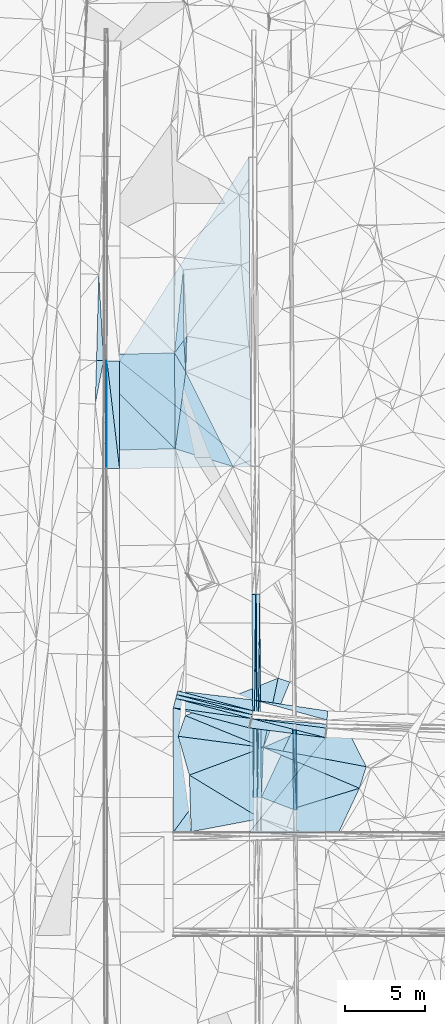
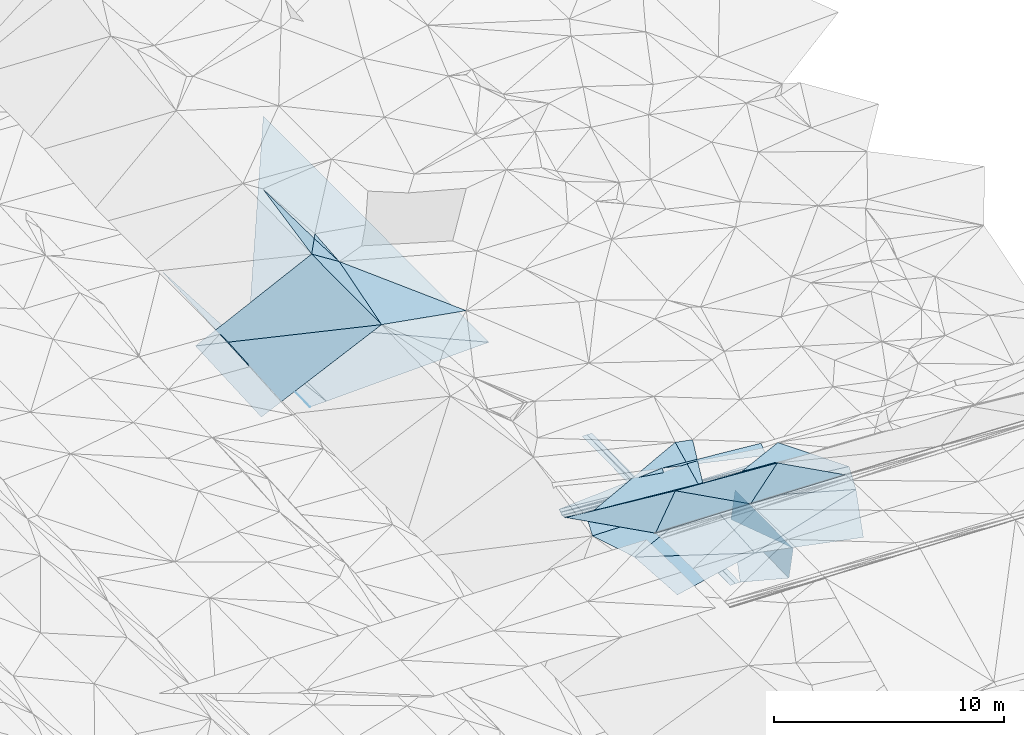
# One storey, part 114 of 275: 46 plates.
"""IFC2X3 building model written with IfcOpenShell, lengths in millimetres."""

from ifc_helpers import new_model, si_unit, frame, origin_with_axes, place, context, subcontext, project, spatial, polyline, outline, extrude, material, type_object, element, save


model = new_model("IFC2X3")

# Units and contexts
model_context = context("Model", 3, precision=1e-05, world=origin_with_axes())
body_context = subcontext(model_context, "Body", "Model", "MODEL_VIEW")
ifc_project = project(units=[si_unit("LENGTHUNIT", "METRE", prefix="MILLI"), si_unit("AREAUNIT", "SQUARE_METRE"), si_unit("VOLUMEUNIT", "CUBIC_METRE"), si_unit("MASSUNIT", "GRAM", prefix="KILO"), si_unit("TIMEUNIT", "SECOND"), si_unit("PLANEANGLEUNIT", "RADIAN"), si_unit("SOLIDANGLEUNIT", "STERADIAN"), si_unit("THERMODYNAMICTEMPERATUREUNIT", "DEGREE_CELSIUS"), si_unit("LUMINOUSINTENSITYUNIT", "LUMEN")], contexts=[model_context])

# Site, building, storey
site_placement = place(None, origin_with_axes())
site = spatial("IfcSite", under=ifc_project, at=site_placement, CompositionType="ELEMENT")
building_placement = place(site_placement, origin_with_axes())
building = spatial("IfcBuilding", under=site, at=building_placement, Name="Undefined", CompositionType="ELEMENT")
storey_placement = place(building_placement, origin_with_axes())
storey = spatial("IfcBuildingStorey", under=building, at=storey_placement, Name="Undefined", CompositionType="ELEMENT", Elevation=0.0)

# Plates
ifc_material = material()
plate_type_1 = type_object("IfcPlateType", PredefinedType="NOTDEFINED")
plate_1_placement = place(storey_placement, frame((-45539.6443262648, 72967.2701989383, 44320.8392892006), z_axis=(0.989902546953071, 0.00964893365161837, -0.141420810403599), x_axis=(0.00717849200956937, -0.999812783623175, -0.0179684989953942)))
element("IfcPlate", 1, at=plate_1_placement, inside=storey, type_object=plate_type_1, material=ifc_material, Name="00_PR", context=body_context, shape_type="SweptSolid", body=[
    extrude(outline(polyline([(0.0, 0.0), (5000.80712890625, -1.83717929758132e-08), (26.9523658752441, 1514.98901367188), (0.0, 0.0)])), frame((-8.85201319254618e-08, 2.18876761149539e-07, -0.5000001331573), z_axis=(0.0, 0.0, 1.0), x_axis=(1.0, 0.0, 0.0)), (0.0, 0.0, 1.0), 1.0),
])
plate_2_placement = place(storey_placement, frame((-45718.0266445742, 67965.859811597, 42730.9822893322), z_axis=(0.989902546953071, 0.00964893365161837, -0.141420810403599), x_axis=(-0.00717838803146426, 0.999812784458858, 0.0179684940352685)))
element("IfcPlate", 2, at=plate_2_placement, inside=storey, type_object=plate_type_1, material=ifc_material, Name="00_PR", context=body_context, shape_type="SweptSolid", body=[
    extrude(outline(polyline([(0.0, 0.0), (5000.80859375, -1.23036443255842e-08), (26.9536952972412, 1514.98913574219), (0.0, 0.0)])), frame((-8.85201319254618e-08, 2.18876761149539e-07, -0.5000001331573), z_axis=(0.0, 0.0, 1.0), x_axis=(1.0, 0.0, 0.0)), (0.0, 0.0, 1.0), 1.0),
])
plate_type_2 = type_object("IfcPlateType", PredefinedType="NOTDEFINED")
plate_3_placement = place(storey_placement, frame((-47974.1287248661, 68735.3194404586, 42758.8477007482), z_axis=(-0.0500548683054502, 0.0172187062398509, -0.998598030397792), x_axis=(0.0124504449974198, 0.99978443948458, 0.0166150830233057)))
element("IfcPlate", 3, at=plate_3_placement, inside=storey, type_object=plate_type_2, material=ifc_material, Name="00_PR", context=body_context, shape_type="SweptSolid", body=[
    extrude(outline(polyline([(0.0, 0.0), (12736.740234375, 5.0415110308677e-08), (4.69877910614014, 250.267730712891), (0.0, 0.0)])), frame((-8.85201319254618e-08, 2.18876761149539e-07, -0.5000001331573), z_axis=(0.0, 0.0, 1.0), x_axis=(1.0, 0.0, 0.0)), (0.0, 0.0, 1.0), 1.0),
])
plate_4_placement = place(storey_placement, frame((-47974.1287248661, 68735.3194404586, 42758.8477007482), z_axis=(-0.0500548683054502, 0.0172187062398509, -0.998598030397792), x_axis=(-0.00717853000391345, 0.999819345250929, 0.0175995900232751)))
element("IfcPlate", 4, at=plate_4_placement, inside=storey, type_object=plate_type_2, material=ifc_material, Name="00_PR", context=body_context, shape_type="SweptSolid", body=[
    extrude(outline(polyline([(0.0, 0.0), (12734.5009765625, 5.47734089195728e-08), (12734.2802734375, 250.311737060547), (0.0, 0.0)])), frame((-8.85201319254618e-08, 2.18876761149539e-07, -0.5000001331573), z_axis=(0.0, 0.0, 1.0), x_axis=(1.0, 0.0, 0.0)), (0.0, 0.0, 1.0), 1.0),
])
for number, where, z_axis, x_axis, name in (
    (5, (-48065.5087683015, 81467.5204068903, 42982.9691776277), (0.0198660327925938, 0.0177391604866168, -0.999645268545955), (0.00717853003015854, -0.999819345250477, -0.0175995900382054), "00_PR"),
    (6, (-48224.0877695375, 68733.5249663157, 42753.8471781702), (0.0198660327925938, 0.0177391604866168, -0.999645268545955), (-0.00717853000391345, 0.999819345250929, 0.0175995900232751), "00_PR"),
):
    element("IfcPlate", number, at=place(storey_placement, frame(where, z_axis=z_axis, x_axis=x_axis)), inside=storey, type_object=plate_type_2, material=ifc_material, Name=name, context=body_context, shape_type="SweptSolid", body=[
        extrude(outline(polyline([(0.0, 0.0), (12734.5009765625, 5.47734089195728e-08), (12734.5888671875, 250.050430297852), (0.0, 0.0)])), frame((-8.85201319254618e-08, 2.18876761149539e-07, -0.5000001331573), z_axis=(0.0, 0.0, 1.0), x_axis=(1.0, 0.0, 0.0)), (0.0, 0.0, 1.0), 1.0),
    ])
plate_5_placement = place(storey_placement, frame((-48262.7019502986, 74164.0690958176, 44924.6477279568), z_axis=(0.103440586504389, -0.0132277407724914, -0.994547672028689), x_axis=(-0.191324335031907, -0.981503003263178, -0.00684495507368622)))
element("IfcPlate", 7, at=plate_5_placement, inside=storey, type_object=plate_type_2, material=ifc_material, Name="00_PR", context=body_context, shape_type="SweptSolid", body=[
    extrude(outline(polyline([(0.0, 0.0), (250.549499511719, -7.71251507103443e-10), (-67.2974319458008, 4895.8701171875), (0.0, 0.0)])), frame((-8.85201319254618e-08, 2.18876761149539e-07, -0.5000001331573), z_axis=(0.0, 0.0, 1.0), x_axis=(1.0, 0.0, 0.0)), (0.0, 0.0, 1.0), 1.0),
])
plate_6_placement = place(storey_placement, frame((-53028.4957575857, 75165.1734921547, 44415.6537173759), z_axis=(0.100633780673037, -0.0265998255595457, -0.994567891834264), x_axis=(0.255546638989038, 0.966796729049807, 7.59026503428096e-11)))
element("IfcPlate", 8, at=plate_6_placement, inside=storey, type_object=plate_type_2, material=ifc_material, Name="00_PR", context=body_context, shape_type="SweptSolid", body=[
    extrude(outline(polyline([(0.0, 0.0), (250.000442504883, 1.2732925824821e-09), (250.011306762695, 4889.94580078125), (0.0, 0.0)])), frame((-8.85201319254618e-08, 2.18876761149539e-07, -0.5000001331573), z_axis=(0.0, 0.0, 1.0), x_axis=(1.0, 0.0, 0.0)), (0.0, 0.0, 1.0), 1.0),
])
plate_7_placement = place(storey_placement, frame((-48310.6399121983, 73918.1473790995, 44922.9326816374), z_axis=(0.0999506617906487, -0.0264806188104818, -0.994639955981573), x_axis=(-0.191324259898436, -0.981502598588607, 0.00690481991997785)))
element("IfcPlate", 9, at=plate_7_placement, inside=storey, type_object=plate_type_2, material=ifc_material, Name="00_PR", context=body_context, shape_type="SweptSolid", body=[
    extrude(outline(polyline([(0.0, 0.0), (250.549606323242, 3.85625753551722e-10), (-75.3704299926758, 4911.9638671875), (0.0, 0.0)])), frame((-8.85201319254618e-08, 2.18876761149539e-07, -0.5000001331573), z_axis=(0.0, 0.0, 1.0), x_axis=(1.0, 0.0, 0.0)), (0.0, 0.0, 1.0), 1.0),
])
plate_8_placement = place(storey_placement, frame((-53092.3819551887, 74923.4743592761, 44415.6536814407), z_axis=(0.0999629807413748, -0.0264221835195045, -0.994640272007604), x_axis=(0.255543618117756, 0.966797527530603, 7.82893553299786e-11)))
element("IfcPlate", 10, at=plate_8_placement, inside=storey, type_object=plate_type_2, material=ifc_material, Name="00_PR", context=body_context, shape_type="SweptSolid", body=[
    extrude(outline(polyline([(0.0, 0.0), (249.99983215332, 4.29281499236822e-10), (249.996047973633, 4906.17724609375), (0.0, 0.0)])), frame((-8.85201319254618e-08, 2.18876761149539e-07, -0.5000001331573), z_axis=(0.0, 0.0, 1.0), x_axis=(1.0, 0.0, 0.0)), (0.0, 0.0, 1.0), 1.0),
])
plate_type_3 = type_object("IfcPlateType", PredefinedType="NOTDEFINED")
plate_9_placement = place(storey_placement, frame((-45754.4198202497, 72965.7362393544, 42820.4100809474), z_axis=(-0.000966419198352467, 0.0179620122290647, -0.999838202986171), x_axis=(0.00717849200956937, -0.999812783623175, -0.0179684989953942)))
element("IfcPlate", 11, at=plate_9_placement, inside=storey, type_object=plate_type_3, material=ifc_material, Name="00_PR", context=body_context, shape_type="SweptSolid", body=[
    extrude(outline(polyline([(0.0, 0.0), (5000.80859375, -1.23036443255842e-08), (4215.02197265625, 2000.00085449219), (0.0, 0.0)])), frame((-8.85201319254618e-08, 2.18876761149539e-07, -0.5000001331573), z_axis=(0.0, 0.0, 1.0), x_axis=(1.0, 0.0, 0.0)), (0.0, 0.0, 1.0), 1.0),
])
plate_type_4 = type_object("IfcPlateType", PredefinedType="NOTDEFINED")
plate_10_placement = place(storey_placement, frame((-57439.7090526211, 89327.6486856889, 42955.6301709706), z_axis=(0.0200084393925659, 0.0165837982033138, -0.999662262961959), x_axis=(0.00147795097401369, 0.999860841220782, 0.0166166739809422)))
element("IfcPlate", 12, at=plate_10_placement, inside=storey, type_object=plate_type_4, material=ifc_material, Name="00_PR", context=body_context, shape_type="SweptSolid", body=[
    extrude(outline(polyline([(0.0, 0.0), (6754.63623046875, 9.31322574615479e-10), (0.0276029277592897, 30.0066394805908), (0.0, 0.0)])), frame((-8.85201319254618e-08, 2.18876761149539e-07, -0.5000001331573), z_axis=(0.0, 0.0, 1.0), x_axis=(1.0, 0.0, 0.0)), (0.0, 0.0, 1.0), 1.0),
])
plate_type_5 = type_object("IfcPlateType", PredefinedType="NOTDEFINED")
plate_11_placement = place(storey_placement, frame((-57609.7084522905, 96086.9620781483, 42947.9563227072), z_axis=(0.031845178116881, 0.0165621058394142, -0.999355583003802), x_axis=(-0.999080390176499, 0.0292480020207374, -0.0313516880338232)))
element("IfcPlate", 13, at=plate_11_placement, inside=storey, type_object=plate_type_5, material=ifc_material, Name="00_PR", context=body_context, shape_type="SweptSolid", body=[
    extrude(outline(polyline([(0.0, 0.0), (443.580596923828, 1.74622982740402e-10), (454.783386230469, 5396.1376953125), (0.0, 0.0)])), frame((-8.85201319254618e-08, 2.18876761149539e-07, -0.5000001331573), z_axis=(0.0, 0.0, 1.0), x_axis=(1.0, 0.0, 0.0)), (0.0, 0.0, 1.0), 1.0),
])
plate_type_6 = type_object("IfcPlateType", PredefinedType="NOTDEFINED")
plate_12_placement = place(storey_placement, frame((-57609.7084539174, 96086.9619930248, 42947.9563213642), z_axis=(0.0318402917802563, 0.0163920253090789, -0.999358542929221), x_axis=(-0.189082696994745, -0.981711838865604, -0.0221268869999383)))
element("IfcPlate", 14, at=plate_12_placement, inside=storey, type_object=plate_type_6, material=ifc_material, Name="00_PR", context=body_context, shape_type="SweptSolid", body=[
    extrude(outline(polyline([(0.0, 0.0), (2766.2724609375, 7.10133463144302e-09), (71.3674240112305, 437.801818847656), (0.0, 0.0)])), frame((-8.85201319254618e-08, 2.18876761149539e-07, -0.5000001331573), z_axis=(0.0, 0.0, 1.0), x_axis=(1.0, 0.0, 0.0)), (0.0, 0.0, 1.0), 1.0),
])
plate_type_7 = type_object("IfcPlateType", PredefinedType="NOTDEFINED")
plate_13_placement = place(storey_placement, frame((-48512.0410634505, 108839.422859126, 43457.2631683329), z_axis=(0.0199768241606193, 0.0165443604288365, -0.999663548717496), x_axis=(0.0071786740281962, -0.999839677812214, -0.0164038200296701)))
element("IfcPlate", 15, at=plate_13_placement, inside=storey, type_object=plate_type_7, material=ifc_material, Name="00_PR", context=body_context, shape_type="SweptSolid", body=[
    extrude(outline(polyline([(0.0, 0.0), (19377.009765625, -3.88390617445111e-08), (12705.7841796875, 8180.73974609375), (0.0, 0.0)])), frame((-8.85201319254618e-08, 2.18876761149539e-07, -0.5000001331573), z_axis=(0.0, 0.0, 1.0), x_axis=(1.0, 0.0, 0.0)), (0.0, 0.0, 1.0), 1.0),
])
plate_type_8 = type_object("IfcPlateType", PredefinedType="NOTDEFINED")
plate_14_placement = place(storey_placement, frame((-56599.7269081778, 96079.6496171847, 43084.469169416), z_axis=(0.0200271346402448, 0.0165859789072501, -0.999661852419002), x_axis=(-0.00147805202816728, -0.999860804224437, -0.0166188909938145)))
element("IfcPlate", 16, at=plate_14_placement, inside=storey, type_object=plate_type_8, material=ifc_material, Name="00_PR", context=body_context, shape_type="SweptSolid", body=[
    extrude(outline(polyline([(0.0, 0.0), (6753.69970703125, 2.5029294192791e-09), (-0.18461748957634, 800.16015625), (0.0, 0.0)])), frame((-8.85201319254618e-08, 2.18876761149539e-07, -0.5000001331573), z_axis=(0.0, 0.0, 1.0), x_axis=(1.0, 0.0, 0.0)), (0.0, 0.0, 1.0), 1.0),
])
plate_15_placement = place(storey_placement, frame((-57409.7084100416, 89327.6219734165, 42956.2301692372), z_axis=(0.0200084393925659, 0.0165837982033138, -0.999662262961959), x_axis=(0.00147795097401369, 0.999860841220782, 0.0166166739809422)))
element("IfcPlate", 17, at=plate_15_placement, inside=storey, type_object=plate_type_8, material=ifc_material, Name="00_PR", context=body_context, shape_type="SweptSolid", body=[
    extrude(outline(polyline([(0.0, 0.0), (6754.6005859375, 2.95331119559705e-08), (0.716363131999969, 800.1591796875), (0.0, 0.0)])), frame((-8.85201319254618e-08, 2.18876761149539e-07, -0.5000001331573), z_axis=(0.0, 0.0, 1.0), x_axis=(1.0, 0.0, 0.0)), (0.0, 0.0, 1.0), 1.0),
])
plate_type_9 = type_object("IfcPlateType", PredefinedType="NOTDEFINED")
plate_16_placement = place(storey_placement, frame((-56609.7092354107, 89326.8900092338, 42972.230169518), z_axis=(0.0200103003487561, 0.0165860093839335, -0.999662189028208), x_axis=(0.00147805202730857, 0.999860804224498, 0.0166188909902079)))
element("IfcPlate", 18, at=plate_16_placement, inside=storey, type_object=plate_type_9, material=ifc_material, Name="00_PR", context=body_context, shape_type="SweptSolid", body=[
    extrude(outline(polyline([(0.0, 0.0), (6753.69970703125, 2.5029294192791e-09), (153.562240600586, 8238.201171875), (0.0, 0.0)])), frame((-8.85201319254618e-08, 2.18876761149539e-07, -0.5000001331573), z_axis=(0.0, 0.0, 1.0), x_axis=(1.0, 0.0, 0.0)), (0.0, 0.0, 1.0), 1.0),
])
plate_type_10 = type_object("IfcPlateType", PredefinedType="NOTDEFINED")
plate_17_placement = place(storey_placement, frame((-48358.6382503304, 73672.0184244944, 44924.7147195084), z_axis=(-0.0242908735813384, -0.454208759542496, -0.890564066317254), x_axis=(-0.170730788994469, -0.875854957969796, 0.451363589901814)))
element("IfcPlate", 19, at=plate_17_placement, inside=storey, type_object=plate_type_10, material=ifc_material, Name="00_PR", context=body_context, shape_type="SweptSolid", body=[
    extrude(outline(polyline([(0.0, 0.0), (673.851440429688, -3.97267285734415e-09), (152.202453613281, 4935.08251953125), (0.0, 0.0)])), frame((-8.85201319254618e-08, 2.18876761149539e-07, -0.5000001331573), z_axis=(0.0, 0.0, 1.0), x_axis=(1.0, 0.0, 0.0)), (0.0, 0.0, 1.0), 1.0),
])
plate_type_11 = type_object("IfcPlateType", PredefinedType="NOTDEFINED")
plate_18_placement = place(storey_placement, frame((-48474.0605865848, 66539.4446934773, 48500.0549206879), z_axis=(-0.0243927288197066, -0.447079344831075, -0.894161648811972), x_axis=(5.12540063995904e-05, 0.894427178851963, -0.447213616858817)))
element("IfcPlate", 20, at=plate_18_placement, inside=storey, type_object=plate_type_11, material=ifc_material, Name="00_PR", context=body_context, shape_type="SweptSolid", body=[
    extrude(outline(polyline([(0.0, 0.0), (7314.6044921875, -5.16811269335449e-08), (6693.85595703125, 4773.57373046875), (0.0, 0.0)])), frame((-8.85201319254618e-08, 2.18876761149539e-07, -0.5000001331573), z_axis=(0.0, 0.0, 1.0), x_axis=(1.0, 0.0, 0.0)), (0.0, 0.0, 1.0), 1.0),
])
plate_type_12 = type_object("IfcPlateType", PredefinedType="NOTDEFINED")
plate_19_placement = place(storey_placement, frame((-53246.2168682699, 66539.7176847084, 48617.4378959695), z_axis=(-0.0220208228492994, -0.447104122786951, -0.894210817843282), x_axis=(5.12540063995904e-05, 0.894427178851963, -0.447213616858817)))
element("IfcPlate", 21, at=plate_19_placement, inside=storey, type_object=plate_type_12, material=ifc_material, Name="00_PR", context=body_context, shape_type="SweptSolid", body=[
    extrude(outline(polyline([(0.0, 0.0), (8724.54296875, 6.00412022322416e-08), (7367.10009765625, 4773.31201171875), (0.0, 0.0)])), frame((-8.85201319254618e-08, 2.18876761149539e-07, -0.5000001331573), z_axis=(0.0, 0.0, 1.0), x_axis=(1.0, 0.0, 0.0)), (0.0, 0.0, 1.0), 1.0),
])
plate_type_13 = type_object("IfcPlateType", PredefinedType="NOTDEFINED")
plate_20_placement = place(storey_placement, frame((-48474.0605865848, 66539.4446934773, 48500.0549206879), z_axis=(-0.0243927288197066, -0.447079344831075, -0.894161648811972), x_axis=(0.580482687080892, 0.721863624140319, -0.376766184977303)))
element("IfcPlate", 22, at=plate_20_placement, inside=storey, type_object=plate_type_13, material=ifc_material, Name="00_PR", context=body_context, shape_type="SweptSolid", body=[
    extrude(outline(polyline([(0.0, 0.0), (8221.6005859375, -2.09547579288483e-09), (2818.9541015625, 3852.77661132813), (0.0, 0.0)])), frame((-8.85201319254618e-08, 2.18876761149539e-07, -0.5000001331573), z_axis=(0.0, 0.0, 1.0), x_axis=(1.0, 0.0, 0.0)), (0.0, 0.0, 1.0), 1.0),
])
plate_type_14 = type_object("IfcPlateType", PredefinedType="NOTDEFINED")
plate_21_placement = place(storey_placement, frame((-53246.2168682699, 66539.7176847084, 48617.4378959695), z_axis=(-0.0220208228492994, -0.447104122786951, -0.894210817843282), x_axis=(0.543673464228605, 0.745258532348684, -0.386016689088896)))
element("IfcPlate", 23, at=plate_21_placement, inside=storey, type_object=plate_type_14, material=ifc_material, Name="00_PR", context=body_context, shape_type="SweptSolid", body=[
    extrude(outline(polyline([(0.0, 0.0), (8778.306640625, 1.43045326694846e-08), (2639.60375976563, 3977.40600585938), (0.0, 0.0)])), frame((-8.85201319254618e-08, 2.18876761149539e-07, -0.5000001331573), z_axis=(0.0, 0.0, 1.0), x_axis=(1.0, 0.0, 0.0)), (0.0, 0.0, 1.0), 1.0),
])
plate_type_15 = type_object("IfcPlateType", PredefinedType="NOTDEFINED")
plate_22_placement = place(storey_placement, frame((-43610.8146264551, 73572.0956377202, 45101.4583526732), z_axis=(0.0905293299970008, 0.440252521428292, -0.893298470717557), x_axis=(-0.963415439831643, 0.265920540903191, 0.0334208949574261)))
element("IfcPlate", 24, at=plate_22_placement, inside=storey, type_object=plate_type_15, material=ifc_material, Name="00_PR", context=body_context, shape_type="SweptSolid", body=[
    extrude(outline(polyline([(0.0, 0.0), (4695.71484375, 4.46743797510862e-09), (115.98274230957, 630.098937988281), (0.0, 0.0)])), frame((-8.85201319254618e-08, 2.18876761149539e-07, -0.5000001331573), z_axis=(0.0, 0.0, 1.0), x_axis=(1.0, 0.0, 0.0)), (0.0, 0.0, 1.0), 1.0),
])
plate_type_16 = type_object("IfcPlateType", PredefinedType="NOTDEFINED")
plate_23_placement = place(storey_placement, frame((-48134.6818194988, 74820.7683392025, 45258.3959572307), z_axis=(0.20490013327842, 0.411477934270702, -0.888088872236783), x_axis=(-0.17120459697413, -0.878284744145285, -0.446435767134061)))
element("IfcPlate", 25, at=plate_23_placement, inside=storey, type_object=plate_type_16, material=ifc_material, Name="00_PR", context=body_context, shape_type="SweptSolid", body=[
    extrude(outline(polyline([(0.0, 0.0), (747.464721679688, 3.70346242561936e-09), (688.14404296875, 4889.5859375), (0.0, 0.0)])), frame((-8.85201319254618e-08, 2.18876761149539e-07, -0.5000001331573), z_axis=(0.0, 0.0, 1.0), x_axis=(1.0, 0.0, 0.0)), (0.0, 0.0, 1.0), 1.0),
])
plate_type_17 = type_object("IfcPlateType", PredefinedType="NOTDEFINED")
plate_24_placement = place(storey_placement, frame((-43620.3708053116, 73322.0544295994, 45101.4053378388), z_axis=(0.0363679451002083, -0.00462977130773667, -0.999327742928628), x_axis=(-0.126284444981451, -0.991994072036586, -6.99828836815705e-11)))
element("IfcPlate", 26, at=plate_24_placement, inside=storey, type_object=plate_type_17, material=ifc_material, Name="00_PR", context=body_context, shape_type="SweptSolid", body=[
    extrude(outline(polyline([(0.0, 0.0), (250.977966308594, 1.0986695997417e-09), (250.979949951172, 4707.7509765625), (0.0, 0.0)])), frame((-8.85201319254618e-08, 2.18876761149539e-07, -0.5000001331573), z_axis=(0.0, 0.0, 1.0), x_axis=(1.0, 0.0, 0.0)), (0.0, 0.0, 1.0), 1.0),
])
plate_type_18 = type_object("IfcPlateType", PredefinedType="NOTDEFINED")
plate_25_placement = place(storey_placement, frame((-43701.563689237, 72474.3186901965, 45402.4340295799), z_axis=(-0.023913197048128, -0.44753956599737, -0.893944347190485), x_axis=(-0.963484868258155, 0.248862174048939, -0.0988156210586275)))
element("IfcPlate", 27, at=plate_25_placement, inside=storey, type_object=plate_type_18, material=ifc_material, Name="00_PR", context=body_context, shape_type="SweptSolid", body=[
    extrude(outline(polyline([(0.0, 0.0), (4792.45068359375, -4.75847627967596e-09), (131.034698486328, 658.878173828125), (0.0, 0.0)])), frame((-8.85201319254618e-08, 2.18876761149539e-07, -0.5000001331573), z_axis=(0.0, 0.0, 1.0), x_axis=(1.0, 0.0, 0.0)), (0.0, 0.0, 1.0), 1.0),
])
plate_type_19 = type_object("IfcPlateType", PredefinedType="NOTDEFINED")
plate_26_placement = place(storey_placement, frame((-48319.0180196499, 73666.9767562705, 44928.8658765447), z_axis=(-0.0249425139927348, -0.450851931207636, -0.892250193119658), x_axis=(0.963484868257055, -0.248862174054929, 0.0988156210542635)))
element("IfcPlate", 28, at=plate_26_placement, inside=storey, type_object=plate_type_19, material=ifc_material, Name="00_PR", context=body_context, shape_type="SweptSolid", body=[
    extrude(outline(polyline([(0.0, 0.0), (4792.45068359375, -4.75847627967596e-09), (26.2470455169678, 675.008850097656), (0.0, 0.0)])), frame((-8.85201319254618e-08, 2.18876761149539e-07, -0.5000001331573), z_axis=(0.0, 0.0, 1.0), x_axis=(1.0, 0.0, 0.0)), (0.0, 0.0, 1.0), 1.0),
])
plate_type_20 = type_object("IfcPlateType", PredefinedType="NOTDEFINED")
plate_27_placement = place(storey_placement, frame((-53245.7702294621, 74343.1825368777, 44715.7057081854), z_axis=(-0.0242842189642688, -0.454166993324796, -0.890585548324028), x_axis=(0.228565298970232, 0.864729789891753, -0.447213924850751)))
element("IfcPlate", 29, at=plate_27_placement, inside=storey, type_object=plate_type_20, material=ifc_material, Name="00_PR", context=body_context, shape_type="SweptSolid", body=[
    extrude(outline(polyline([(0.0, 0.0), (670.819885253906, 3.93629306927323e-09), (443.181457519531, 4917.4990234375), (0.0, 0.0)])), frame((-8.85201319254618e-08, 2.18876761149539e-07, -0.5000001331573), z_axis=(0.0, 0.0, 1.0), x_axis=(1.0, 0.0, 0.0)), (0.0, 0.0, 1.0), 1.0),
])
plate_type_21 = type_object("IfcPlateType", PredefinedType="NOTDEFINED")
plate_28_placement = place(storey_placement, frame((-53124.458221145, 90561.7752730459, 45075.5044221676), z_axis=(0.131370884246141, 0.0197189332862792, -0.991137152185528), x_axis=(-0.00702116664561855, 0.99979557910624, 0.0189605701009185)))
element("IfcPlate", 30, at=plate_28_placement, inside=storey, type_object=plate_type_21, material=ifc_material, Name="00", context=body_context, shape_type="SweptSolid", body=[
    extrude(outline(polyline([(0.0, 0.0), (6012.4775390625, 1.18234311230481e-08), (4829.5, 702.982788085938), (0.0, 0.0)])), frame((-8.85201319254618e-08, 2.18876761149539e-07, -0.5000001331573), z_axis=(0.0, 0.0, 1.0), x_axis=(1.0, 0.0, 0.0)), (0.0, 0.0, 1.0), 1.0),
])
plate_type_22 = type_object("IfcPlateType", PredefinedType="NOTDEFINED")
plate_29_placement = place(storey_placement, frame((-47600.5398798422, 71859.2908967304, 45199.502472511), z_axis=(0.0943749212211561, 0.0315237416597516, -0.995037500778875), x_axis=(-0.987505143692094, 0.129668591392095, -0.0895524851025708)))
element("IfcPlate", 31, at=plate_29_placement, inside=storey, type_object=plate_type_22, material=ifc_material, Name="00", context=body_context, shape_type="SweptSolid", body=[
    extrude(outline(polyline([(0.0, 0.0), (5404.65185546875, 1.94122549146414e-08), (5117.5322265625, 1344.04736328125), (0.0, 0.0)])), frame((-8.85201319254618e-08, 2.18876761149539e-07, -0.5000001331573), z_axis=(0.0, 0.0, 1.0), x_axis=(1.0, 0.0, 0.0)), (0.0, 0.0, 1.0), 1.0),
])
plate_type_23 = type_object("IfcPlateType", PredefinedType="NOTDEFINED")
plate_30_placement = place(storey_placement, frame((-52461.4784110177, 95393.4416738201, 45259.5071733952), z_axis=(0.162867122950313, 0.0446687158379654, -0.985636345762104), x_axis=(-0.0591967766141338, 0.99761739055537, 0.035429983065055)))
element("IfcPlate", 32, at=plate_30_placement, inside=storey, type_object=plate_type_23, material=ifc_material, Name="00", context=body_context, shape_type="SweptSolid", body=[
    extrude(outline(polyline([(0.0, 0.0), (1975.72766113281, -7.77799868956208e-09), (2217.76513671875, 190.309997558594), (0.0, 0.0)])), frame((-8.85201319254618e-08, 2.18876761149539e-07, -0.5000001331573), z_axis=(0.0, 0.0, 1.0), x_axis=(1.0, 0.0, 0.0)), (0.0, 0.0, 1.0), 1.0),
])
plate_type_24 = type_object("IfcPlateType", PredefinedType="NOTDEFINED")
plate_31_placement = place(storey_placement, frame((-52615.4268895607, 101776.197647914, 45299.5142921735), z_axis=(0.237404885256343, -0.00461292526271902, -0.971399835998001), x_axis=(0.00839276662518913, -0.999941661685054, 0.0067996099086042)))
element("IfcPlate", 33, at=plate_31_placement, inside=storey, type_object=plate_type_24, material=ifc_material, Name="00", context=body_context, shape_type="SweptSolid", body=[
    extrude(outline(polyline([(0.0, 0.0), (4412.017578125, 1.6858393792063e-08), (5197.5087890625, 612.343017578125), (0.0, 0.0)])), frame((-8.85201319254618e-08, 2.18876761149539e-07, -0.5000001331573), z_axis=(0.0, 0.0, 1.0), x_axis=(1.0, 0.0, 0.0)), (0.0, 0.0, 1.0), 1.0),
])
plate_type_25 = type_object("IfcPlateType", PredefinedType="NOTDEFINED")
plate_32_placement = place(storey_placement, frame((-49510.3984401463, 89460.0386473187, 45219.5008439142), z_axis=(0.0493031017539943, 0.0312522505320516, -0.998294796637805), x_axis=(-0.955847221353079, 0.291385730439015, -0.0380847151508221)))
element("IfcPlate", 34, at=plate_32_placement, inside=storey, type_object=plate_type_25, material=ifc_material, Name="00", context=body_context, shape_type="SweptSolid", body=[
    extrude(outline(polyline([(0.0, 0.0), (3781.04443359375, 1.74622982740402e-10), (4548.2197265625, 4819.7197265625), (0.0, 0.0)])), frame((-8.85201319254618e-08, 2.18876761149539e-07, -0.5000001331573), z_axis=(0.0, 0.0, 1.0), x_axis=(1.0, 0.0, 0.0)), (0.0, 0.0, 1.0), 1.0),
])
plate_type_26 = type_object("IfcPlateType", PredefinedType="NOTDEFINED")
plate_33_placement = place(storey_placement, frame((-52235.9620478232, 70127.0452666446, 44819.5020072182), z_axis=(0.0880646997981289, -0.0171741563012291, -0.995966694726689), x_axis=(-0.276878173614847, 0.96002838095996, -0.0410363829680908)))
element("IfcPlate", 35, at=plate_33_placement, inside=storey, type_object=plate_type_26, material=ifc_material, Name="00", context=body_context, shape_type="SweptSolid", body=[
    extrude(outline(polyline([(0.0, 0.0), (2534.33642578125, 1.54614099301398e-09), (363.941436767578, 4949.7119140625), (0.0, 0.0)])), frame((-8.85201319254618e-08, 2.18876761149539e-07, -0.5000001331573), z_axis=(0.0, 0.0, 1.0), x_axis=(1.0, 0.0, 0.0)), (0.0, 0.0, 1.0), 1.0),
])
plate_type_27 = type_object("IfcPlateType", PredefinedType="NOTDEFINED")
plate_34_placement = place(storey_placement, frame((-52461.4731904558, 95393.4419513969, 45259.5080772705), z_axis=(0.17330947645509, 0.0452241435219296, -0.983828543097612), x_axis=(-0.512451478448133, 0.857208169522834, -0.0508688150012802)))
element("IfcPlate", 36, at=plate_34_placement, inside=storey, type_object=plate_type_27, material=ifc_material, Name="00", context=body_context, shape_type="SweptSolid", body=[
    extrude(outline(polyline([(0.0, 0.0), (1376.08862304688, 7.37054506316781e-09), (1745.94860839844, 924.750610351563), (0.0, 0.0)])), frame((-8.85201319254618e-08, 2.18876761149539e-07, -0.5000001331573), z_axis=(0.0, 0.0, 1.0), x_axis=(1.0, 0.0, 0.0)), (0.0, 0.0, 1.0), 1.0),
])
plate_type_28 = type_object("IfcPlateType", PredefinedType="NOTDEFINED")
plate_35_placement = place(storey_placement, frame((-47600.5650709753, 71859.2796609233, 45199.5004955937), z_axis=(0.0439995932121014, 0.00905563441232492, -0.998990506102315), x_axis=(0.207667202357567, 0.978033687945535, 0.0180121711250355)))
element("IfcPlate", 37, at=plate_35_placement, inside=storey, type_object=plate_type_28, material=ifc_material, Name="00", context=body_context, shape_type="SweptSolid", body=[
    extrude(outline(polyline([(0.0, 0.0), (4441.44140625, -6.11908035352826e-09), (4354.17236328125, 767.1923828125), (0.0, 0.0)])), frame((-8.85201319254618e-08, 2.18876761149539e-07, -0.5000001331573), z_axis=(0.0, 0.0, 1.0), x_axis=(1.0, 0.0, 0.0)), (0.0, 0.0, 1.0), 1.0),
])
plate_type_29 = type_object("IfcPlateType", PredefinedType="NOTDEFINED")
plate_36_placement = place(storey_placement, frame((-41152.4322913418, 70653.5679754595, 45429.5004071537), z_axis=(0.0306094436693378, -0.0269015148300499, -0.999169340231225), x_axis=(-0.982360451816354, 0.183684893355743, -0.0350400151263864)))
element("IfcPlate", 38, at=plate_36_placement, inside=storey, type_object=plate_type_29, material=ifc_material, Name="00", context=body_context, shape_type="SweptSolid", body=[
    extrude(outline(polyline([(0.0, 0.0), (6563.92431640625, -2.82307155430317e-09), (2255.37353515625, 2930.69799804688), (0.0, 0.0)])), frame((-8.85201319254618e-08, 2.18876761149539e-07, -0.5000001331573), z_axis=(0.0, 0.0, 1.0), x_axis=(1.0, 0.0, 0.0)), (0.0, 0.0, 1.0), 1.0),
])
plate_type_30 = type_object("IfcPlateType", PredefinedType="NOTDEFINED")
plate_37_placement = place(storey_placement, frame((-47600.5849524642, 71859.284035231, 45199.500074462), z_axis=(0.00423418025005056, 0.017796140548124, -0.999832670550028), x_axis=(0.920435069975758, -0.390883514328744, -0.00305944189892388)))
element("IfcPlate", 39, at=plate_37_placement, inside=storey, type_object=plate_type_30, material=ifc_material, Name="00", context=body_context, shape_type="SweptSolid", body=[
    extrude(outline(polyline([(0.0, 0.0), (6537.14013671875, 6.79574441164732e-09), (1592.86779785156, 4165.5458984375), (0.0, 0.0)])), frame((-8.85201319254618e-08, 2.18876761149539e-07, -0.5000001331573), z_axis=(0.0, 0.0, 1.0), x_axis=(1.0, 0.0, 0.0)), (0.0, 0.0, 1.0), 1.0),
])
plate_type_31 = type_object("IfcPlateType", PredefinedType="NOTDEFINED")
plate_38_placement = place(storey_placement, frame((-46678.204396256, 76203.1547328448, 45279.5016758139), z_axis=(0.0820094104758821, 0.000941506683113834, -0.996631110370614), x_axis=(-0.207667202365341, -0.97803368794414, -0.0180121711111262)))
element("IfcPlate", 40, at=plate_38_placement, inside=storey, type_object=plate_type_31, material=ifc_material, Name="00", context=body_context, shape_type="SweptSolid", body=[
    extrude(outline(polyline([(0.0, 0.0), (4441.44140625, -6.11908035352826e-09), (3511.11254882813, 5208.6552734375), (0.0, 0.0)])), frame((-8.85201319254618e-08, 2.18876761149539e-07, -0.5000001331573), z_axis=(0.0, 0.0, 1.0), x_axis=(1.0, 0.0, 0.0)), (0.0, 0.0, 1.0), 1.0),
])
plate_type_32 = type_object("IfcPlateType", PredefinedType="NOTDEFINED")
plate_39_placement = place(storey_placement, frame((-41152.4149302495, 70653.6622035423, 45429.5076410971), z_axis=(0.0653289560456427, 0.161540960592662, -0.984701297629279), x_axis=(-0.299675360529332, -0.938081587541326, -0.173774605186029)))
element("IfcPlate", 41, at=plate_39_placement, inside=storey, type_object=plate_type_32, material=ifc_material, Name="00", context=body_context, shape_type="SweptSolid", body=[
    extrude(outline(polyline([(0.0, 0.0), (1438.64514160156, -9.64791979640722e-09), (841.277587890625, 6509.7890625), (0.0, 0.0)])), frame((-8.85201319254618e-08, 2.18876761149539e-07, -0.5000001331573), z_axis=(0.0, 0.0, 1.0), x_axis=(1.0, 0.0, 0.0)), (0.0, 0.0, 1.0), 1.0),
])
plate_type_33 = type_object("IfcPlateType", PredefinedType="NOTDEFINED")
plate_40_placement = place(storey_placement, frame((-47762.6280673363, 67403.2167323507, 45119.5008110305), z_axis=(0.0502850850034828, -0.0273751111198475, -0.998359661403328), x_axis=(-0.981625296176057, -0.185592475651113, -0.0443532511656)))
element("IfcPlate", 42, at=plate_40_placement, inside=storey, type_object=plate_type_33, material=ifc_material, Name="00", context=body_context, shape_type="SweptSolid", body=[
    extrude(outline(polyline([(0.0, 0.0), (4441.61376953125, 8.36735125631094e-09), (3898.94116210938, 3509.75170898438), (0.0, 0.0)])), frame((-8.85201319254618e-08, 2.18876761149539e-07, -0.5000001331573), z_axis=(0.0, 0.0, 1.0), x_axis=(1.0, 0.0, 0.0)), (0.0, 0.0, 1.0), 1.0),
])
plate_type_34 = type_object("IfcPlateType", PredefinedType="NOTDEFINED")
plate_41_placement = place(storey_placement, frame((-47600.5490329693, 71859.2827098998, 45199.5014979932), z_axis=(0.076075723355643, 0.0151321816075884, -0.996987212252851), x_axis=(-0.0363400743827861, -0.99917846908545, -0.0179383920658812)))
element("IfcPlate", 43, at=plate_41_placement, inside=storey, type_object=plate_type_34, material=ifc_material, Name="00", context=body_context, shape_type="SweptSolid", body=[
    extrude(outline(polyline([(0.0, 0.0), (4459.70849609375, -2.17332853935659e-08), (1906.06628417969, 4582.4677734375), (0.0, 0.0)])), frame((-8.85201319254618e-08, 2.18876761149539e-07, -0.5000001331573), z_axis=(0.0, 0.0, 1.0), x_axis=(1.0, 0.0, 0.0)), (0.0, 0.0, 1.0), 1.0),
])
plate_type_35 = type_object("IfcPlateType", PredefinedType="NOTDEFINED")
plate_42_placement = place(storey_placement, frame((-43187.4220071633, 65883.3918446537, 45269.5004257189), z_axis=(0.0207866797957718, -0.0360348469433778, -0.999134327179702), x_axis=(-0.948550660126325, 0.315094473386668, -0.0310985211077812)))
element("IfcPlate", 44, at=plate_42_placement, inside=storey, type_object=plate_type_35, material=ifc_material, Name="00", context=body_context, shape_type="SweptSolid", body=[
    extrude(outline(polyline([(0.0, 0.0), (4823.38037109375, -8.21455614641309e-09), (-440.728240966797, 3753.23315429688), (0.0, 0.0)])), frame((-8.85201319254618e-08, 2.18876761149539e-07, -0.5000001331573), z_axis=(0.0, 0.0, 1.0), x_axis=(1.0, 0.0, 0.0)), (0.0, 0.0, 1.0), 1.0),
])
plate_type_36 = type_object("IfcPlateType", PredefinedType="NOTDEFINED")
plate_43_placement = place(storey_placement, frame((-59229.9384661782, 90446.1250108789, 42373.5427550654), z_axis=(0.404631654192205, 0.00330602847660803, -0.914473780160695), x_axis=(0.0257504894053504, 0.999555743992223, 0.0150075630112977)))
element("IfcPlate", 45, at=plate_43_placement, inside=storey, type_object=plate_type_36, material=ifc_material, Name="00", context=body_context, shape_type="SweptSolid", body=[
    extrude(outline(polyline([(0.0, 0.0), (5996.9765625, -6.02449290454388e-09), (313.363739013672, 6670.42236328125), (0.0, 0.0)])), frame((-8.85201319254618e-08, 2.18876761149539e-07, -0.5000001331573), z_axis=(0.0, 0.0, 1.0), x_axis=(1.0, 0.0, 0.0)), (0.0, 0.0, 1.0), 1.0),
])
plate_type_37 = type_object("IfcPlateType", PredefinedType="NOTDEFINED")
plate_44_placement = place(storey_placement, frame((-53166.5293322199, 96573.0238752306, 45189.5459838676), z_axis=(0.418445504167783, 0.0201586384348495, -0.90801816575343), x_axis=(0.00702116658339803, -0.999795579108505, -0.0189605700045525)))
element("IfcPlate", 46, at=plate_44_placement, inside=storey, type_object=plate_type_37, material=ifc_material, Name="00", context=body_context, shape_type="SweptSolid", body=[
    extrude(outline(polyline([(0.0, 0.0), (6012.4775390625, 1.18234311230481e-08), (142.749801635742, 6507.24853515625), (0.0, 0.0)])), frame((-8.85201319254618e-08, 2.18876761149539e-07, -0.5000001331573), z_axis=(0.0, 0.0, 1.0), x_axis=(1.0, 0.0, 0.0)), (0.0, 0.0, 1.0), 1.0),
])

save(model, "model.ifc")
